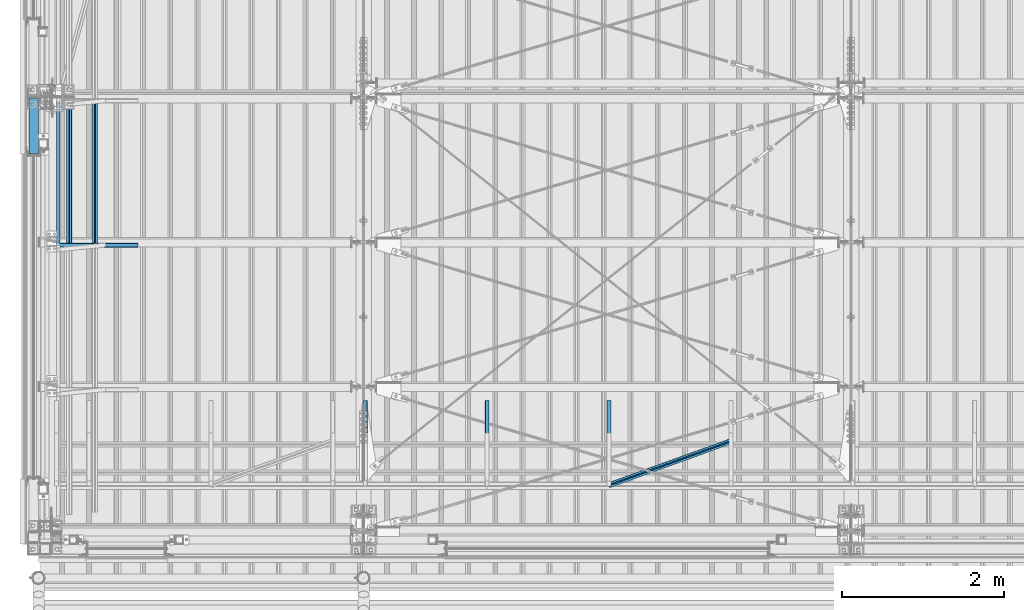
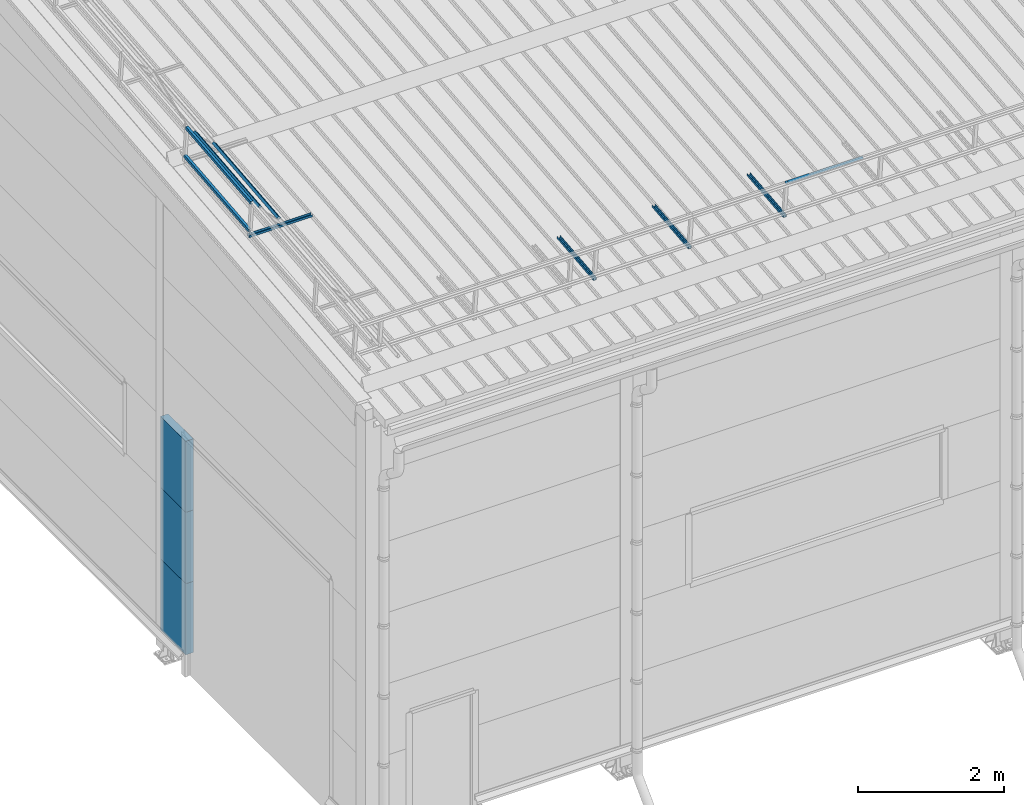
# One storey, part 31 of 709: 12 beams, 12 elements without a shape of their own.
"""IFC4 building model written with IfcOpenShell, lengths in millimetres."""

from ifc_helpers import new_model, si_unit, direction, frame, origin_with_axes, place, context, subcontext, project, spatial, line, indexed_curve, outline, extrude, material, element, aggregate, save


model = new_model("IFC4")

# Units and contexts
model_context = context("Model", 3, precision=0.2, world=origin_with_axes(), true_north=direction((0.0, 1.0)))
body_context = subcontext(model_context, "Body", "Model", "MODEL_VIEW")
ifc_project = project(units=[si_unit("LENGTHUNIT", "METRE", prefix="MILLI"), si_unit("AREAUNIT", "SQUARE_METRE"), si_unit("VOLUMEUNIT", "CUBIC_METRE"), si_unit("MASSUNIT", "GRAM", prefix="KILO"), si_unit("TIMEUNIT", "SECOND"), si_unit("PLANEANGLEUNIT", "RADIAN"), si_unit("SOLIDANGLEUNIT", "STERADIAN"), si_unit("THERMODYNAMICTEMPERATUREUNIT", "DEGREE_CELSIUS"), si_unit("LUMINOUSINTENSITYUNIT", "LUMEN")], contexts=[model_context])

# Site, building, storey
site_placement = place(None, origin_with_axes())
site = spatial("IfcSite", under=ifc_project, at=site_placement, CompositionType="ELEMENT")
building_placement = place(site_placement, origin_with_axes())
building = spatial("IfcBuilding", under=site, at=building_placement, Name="Undefined", CompositionType="ELEMENT")
storey_placement = place(building_placement, origin_with_axes())
storey = spatial("IfcBuildingStorey", under=building, at=storey_placement, Name="Undefined", CompositionType="ELEMENT", Elevation=0.0)

# Assembly, beam
assembly_1_placement = place(storey_placement, frame((4020.0, 768.92298, 7577.16191), z_axis=(0.0, -0.099503719, 0.9950371902), x_axis=(0.0, 0.9950371902, 0.099503719)))
assembly_1 = element("IfcElementAssembly", 1, at=assembly_1_placement, inside=storey)
ifc_material_1 = material(Name="Steel_Undefined", Category="STEEL")
beam_1_placement = place(assembly_1_placement, origin_with_axes())
beam_1 = element("IfcBeam", 2, at=beam_1_placement, material=ifc_material_1, ObjectType="601", context=body_context, shape_type="SolidModel", body=[
    extrude(outline(indexed_curve([(-20.0, -25.0), (20.0, -25.0), (20.0, -22.5), (-17.5, -22.5), (-17.5, 22.5), (20.0, 22.5), (20.0, 25.0), (-20.0, 25.0)], segments=[line(1, 2, 3, 4, 5, 6, 7, 8, 1)])), frame((0.0, 0.0, 0.0), z_axis=(-1.0, 0.0, 0.0), x_axis=(0.0, 0.0, 1.0)), (0.0, 0.0, -1.0), 1000.0),
])
aggregate(assembly_1, [beam_1])

assembly_2_placement = place(storey_placement, frame((5520.0, 768.92298, 7577.16191), z_axis=(0.0, -0.099503719, 0.9950371902), x_axis=(0.0, 0.9950371902, 0.099503719)))
assembly_2 = element("IfcElementAssembly", 3, at=assembly_2_placement, inside=storey)
beam_2_placement = place(assembly_2_placement, origin_with_axes())
beam_2 = element("IfcBeam", 4, at=beam_2_placement, material=ifc_material_1, ObjectType="601", context=body_context, shape_type="SolidModel", body=[
    extrude(outline(indexed_curve([(-20.0, -25.0), (20.0, -25.0), (20.0, -22.5), (-17.5, -22.5), (-17.5, 22.5), (20.0, 22.5), (20.0, 25.0), (-20.0, 25.0)], segments=[line(1, 2, 3, 4, 5, 6, 7, 8, 1)])), frame((0.0, 0.0, 0.0), z_axis=(-1.0, 0.0, 0.0), x_axis=(0.0, 0.0, 1.0)), (0.0, 0.0, -1.0), 1000.0),
])
aggregate(assembly_2, [beam_2])

assembly_3_placement = place(storey_placement, frame((7020.0, 768.92298, 7577.16191), z_axis=(0.0, -0.099503719, 0.9950371902), x_axis=(0.0, 0.9950371902, 0.099503719)))
assembly_3 = element("IfcElementAssembly", 5, at=assembly_3_placement, inside=storey)
beam_3_placement = place(assembly_3_placement, origin_with_axes())
beam_3 = element("IfcBeam", 6, at=beam_3_placement, material=ifc_material_1, ObjectType="601", context=body_context, shape_type="SolidModel", body=[
    extrude(outline(indexed_curve([(-20.0, -25.0), (20.0, -25.0), (20.0, -22.5), (-17.5, -22.5), (-17.5, 22.5), (20.0, 22.5), (20.0, 25.0), (-20.0, 25.0)], segments=[line(1, 2, 3, 4, 5, 6, 7, 8, 1)])), frame((0.0, 0.0, 0.0), z_axis=(-1.0, 0.0, 0.0), x_axis=(0.0, 0.0, 1.0)), (0.0, 0.0, -1.0), 1000.0),
])
aggregate(assembly_3, [beam_3])

assembly_4_placement = place(storey_placement, frame((7020.0, 723.87558, 8169.76263), z_axis=(0.0, 0.6332377902, 0.7739572992), x_axis=(0.9061831398, 0.3272952929, -0.2677870579)))
assembly_4 = element("IfcElementAssembly", 7, at=assembly_4_placement, inside=storey)
beam_4_placement = place(assembly_4_placement, origin_with_axes())
beam_4 = element("IfcBeam", 8, at=beam_4_placement, material=ifc_material_1, ObjectType="605", context=body_context, shape_type="SolidModel", body=[
    extrude(outline(indexed_curve([(-20.0, -25.0), (20.0, -25.0), (20.0, -22.5), (-17.5, -22.5), (-17.5, 22.5), (20.0, 22.5), (20.0, 25.0), (-20.0, 25.0)], segments=[line(1, 2, 3, 4, 5, 6, 7, 8, 1)])), frame((0.0, 0.0, 0.0), z_axis=(-1.0, 0.0, 0.0), x_axis=(0.0, 0.0, 1.0)), (0.0, 0.0, -1.0), 1655.29454),
])
aggregate(assembly_4, [beam_4])

assembly_5_placement = place(storey_placement, frame((220.0, 3676.5335, 7867.92296), z_axis=(0.0, -0.099503719, 0.9950371902), x_axis=(1.0, 0.0, 0.0)))
assembly_5 = element("IfcElementAssembly", 9, at=assembly_5_placement, inside=storey)
beam_5_placement = place(assembly_5_placement, origin_with_axes())
beam_5 = element("IfcBeam", 10, at=beam_5_placement, material=ifc_material_1, ObjectType="601", context=body_context, shape_type="SolidModel", body=[
    extrude(outline(indexed_curve([(-20.0, -25.0), (20.0, -25.0), (20.0, -22.5), (-17.5, -22.5), (-17.5, 22.5), (20.0, 22.5), (20.0, 25.0), (-20.0, 25.0)], segments=[line(1, 2, 3, 4, 5, 6, 7, 8, 1)])), frame((0.0, 0.0, 0.0), z_axis=(-1.0, 0.0, 0.0), x_axis=(0.0, 0.0, 1.0)), (0.0, 0.0, -1.0), 1000.0),
])
aggregate(assembly_5, [beam_5])

assembly_6_placement = place(storey_placement, frame((240.0, 3618.82134, 8445.04453), z_axis=(1.0, 0.0, 0.0), x_axis=(0.0, 0.9950371902, 0.099503719)))
assembly_6 = element("IfcElementAssembly", 11, at=assembly_6_placement, inside=storey)
beam_6_placement = place(assembly_6_placement, origin_with_axes())
beam_6 = element("IfcBeam", 12, at=beam_6_placement, material=ifc_material_1, ObjectType="609", context=body_context, shape_type="SolidModel", body=[
    extrude(outline(indexed_curve([(-20.0, -25.0), (20.0, -25.0), (20.0, -22.5), (-17.5, -22.5), (-17.5, 22.5), (20.0, 22.5), (20.0, 25.0), (-20.0, 25.0)], segments=[line(1, 2, 3, 4, 5, 6, 7, 8, 1)])), frame((0.0, 0.0, 0.0), z_axis=(-1.0, 0.0, 0.0), x_axis=(0.0, 0.0, 1.0)), (0.0, 0.0, -1.0), 1785.56115),
])
aggregate(assembly_6, [beam_6])

assembly_7_placement = place(storey_placement, frame((240.0, 3668.5732, 7947.52594), z_axis=(1.0, 0.0, 0.0), x_axis=(0.0, 0.9950371902, 0.099503719)))
assembly_7 = element("IfcElementAssembly", 13, at=assembly_7_placement, inside=storey)
beam_7_placement = place(assembly_7_placement, origin_with_axes())
beam_7 = element("IfcBeam", 14, at=beam_7_placement, material=ifc_material_1, ObjectType="609", context=body_context, shape_type="SolidModel", body=[
    extrude(outline(indexed_curve([(-20.0, -25.0), (20.0, -25.0), (20.0, -22.5), (-17.5, -22.5), (-17.5, 22.5), (20.0, 22.5), (20.0, 25.0), (-20.0, 25.0)], segments=[line(1, 2, 3, 4, 5, 6, 7, 8, 1)])), frame((0.0, 0.0, 0.0), z_axis=(-1.0, 0.0, 0.0), x_axis=(0.0, 0.0, 1.0)), (0.0, 0.0, -1.0), 1785.56115),
])
aggregate(assembly_7, [beam_7])

assembly_8_placement = place(storey_placement, frame((375.56349, 3631.4861, 8318.39698), z_axis=(0.7071067814, -0.0703597545, 0.7035975445), x_axis=(0.0, 0.9950371902, 0.099503719)))
assembly_8 = element("IfcElementAssembly", 15, at=assembly_8_placement, inside=storey)
beam_8_placement = place(assembly_8_placement, origin_with_axes())
beam_8 = element("IfcBeam", 16, at=beam_8_placement, material=ifc_material_1, ObjectType="609", context=body_context, shape_type="SolidModel", body=[
    extrude(outline(indexed_curve([(-20.0, -25.0), (20.0, -25.0), (20.0, -22.5), (-17.5, -22.5), (-17.5, 22.5), (20.0, 22.5), (20.0, 25.0), (-20.0, 25.0)], segments=[line(1, 2, 3, 4, 5, 6, 7, 8, 1)])), frame((0.0, 0.0, 0.0), z_axis=(-1.0, 0.0, 0.0), x_axis=(0.0, 0.0, 1.0)), (0.0, 0.0, -1.0), 1785.56115),
])
aggregate(assembly_8, [beam_8])

assembly_9_placement = place(storey_placement, frame((692.72078, 3663.04443, 8002.81368), z_axis=(0.7071067814, -0.0703597545, 0.7035975445), x_axis=(0.0, 0.9950371902, 0.099503719)))
assembly_9 = element("IfcElementAssembly", 17, at=assembly_9_placement, inside=storey)
beam_9_placement = place(assembly_9_placement, origin_with_axes())
beam_9 = element("IfcBeam", 18, at=beam_9_placement, material=ifc_material_1, ObjectType="609", context=body_context, shape_type="SolidModel", body=[
    extrude(outline(indexed_curve([(-20.0, -25.0), (20.0, -25.0), (20.0, -22.5), (-17.5, -22.5), (-17.5, 22.5), (20.0, 22.5), (20.0, 25.0), (-20.0, 25.0)], segments=[line(1, 2, 3, 4, 5, 6, 7, 8, 1)])), frame((0.0, 0.0, 0.0), z_axis=(-1.0, 0.0, 0.0), x_axis=(0.0, 0.0, 1.0)), (0.0, 0.0, -1.0), 1785.56115),
])
aggregate(assembly_9, [beam_9])

assembly_10_placement = place(storey_placement, frame((-60.0, 4800.0, 895.0), z_axis=(0.0, 0.0, -1.0), x_axis=(0.0, 1.0, 0.0)))
assembly_10 = element("IfcElementAssembly", 19, at=assembly_10_placement, inside=storey)
ifc_material_2 = material(Name="Insulation", Category="Insulation")
beam_10_placement = place(assembly_10_placement, origin_with_axes())
beam_10 = element("IfcBeam", 20, at=beam_10_placement, material=ifc_material_2, ObjectType="P-134", context=body_context, shape_type="SolidModel", body=[
    extrude(outline(indexed_curve([(-595.0, -60.0), (595.0, -60.0), (595.0, 60.0), (-595.0, 60.0)], segments=[line(1, 2, 3, 4, 1)])), frame((0.0, 0.0, 0.0), z_axis=(-1.0, 0.0, 0.0), x_axis=(0.0, 0.0, 1.0)), (0.0, 0.0, -1.0), 690.0),
])
aggregate(assembly_10, [beam_10])

assembly_11_placement = place(storey_placement, frame((-60.0, 4800.0, 2085.0), z_axis=(0.0, 0.0, -1.0), x_axis=(0.0, 1.0, 0.0)))
assembly_11 = element("IfcElementAssembly", 21, at=assembly_11_placement, inside=storey)
beam_11_placement = place(assembly_11_placement, origin_with_axes())
beam_11 = element("IfcBeam", 22, at=beam_11_placement, material=ifc_material_2, ObjectType="P-134", context=body_context, shape_type="SolidModel", body=[
    extrude(outline(indexed_curve([(-595.0, -60.0), (595.0, -60.0), (595.0, 60.0), (-595.0, 60.0)], segments=[line(1, 2, 3, 4, 1)])), frame((0.0, 0.0, 0.0), z_axis=(-1.0, 0.0, 0.0), x_axis=(0.0, 0.0, 1.0)), (0.0, 0.0, -1.0), 690.0),
])
aggregate(assembly_11, [beam_11])

assembly_12_placement = place(storey_placement, frame((-60.0, 4800.0, 3275.0), z_axis=(0.0, 0.0, -1.0), x_axis=(0.0, 1.0, 0.0)))
assembly_12 = element("IfcElementAssembly", 23, at=assembly_12_placement, inside=storey)
beam_12_placement = place(assembly_12_placement, origin_with_axes())
beam_12 = element("IfcBeam", 24, at=beam_12_placement, material=ifc_material_2, ObjectType="P-134", context=body_context, shape_type="SolidModel", body=[
    extrude(outline(indexed_curve([(-595.0, -60.0), (595.0, -60.0), (595.0, 60.0), (-595.0, 60.0)], segments=[line(1, 2, 3, 4, 1)])), frame((0.0, 0.0, 0.0), z_axis=(-1.0, 0.0, 0.0), x_axis=(0.0, 0.0, 1.0)), (0.0, 0.0, -1.0), 690.0),
])
aggregate(assembly_12, [beam_12])

save(model, "model.ifc")
